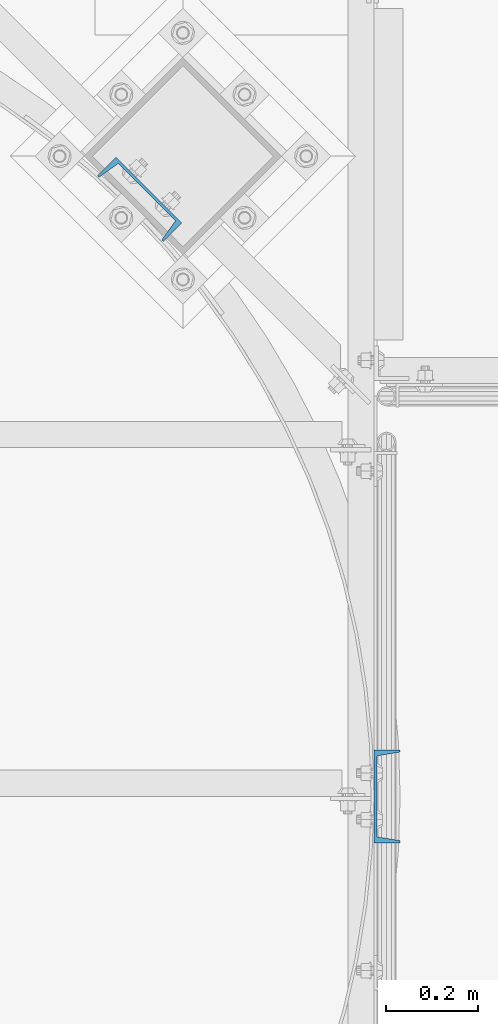
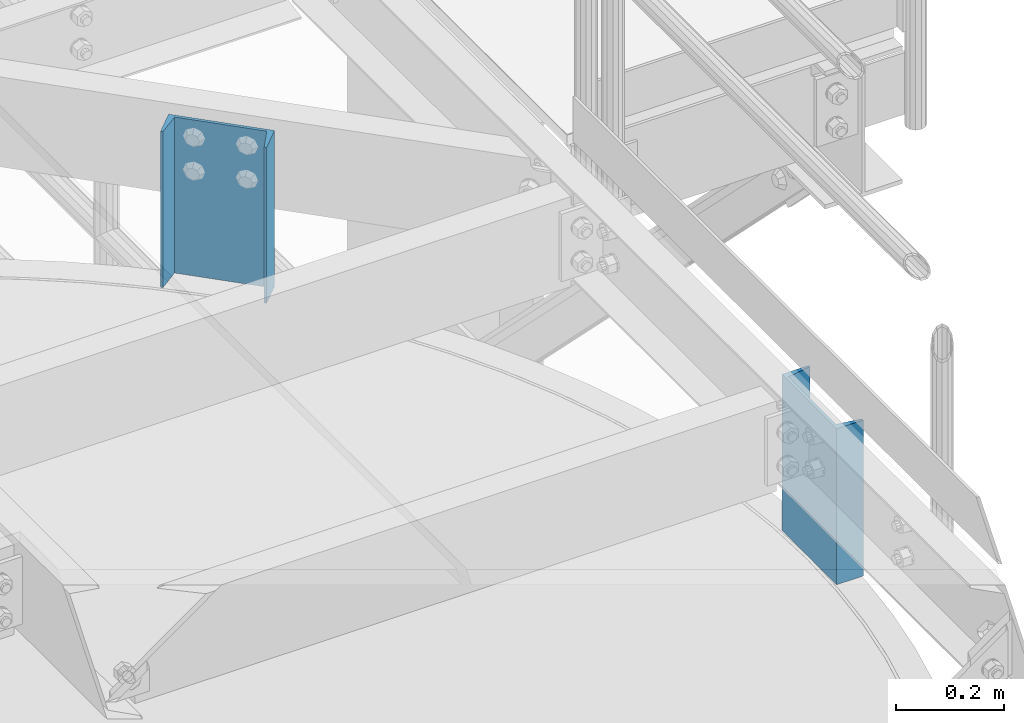
# One storey, part 807 of 1876: 2 columns, 2 elements without a shape of their own.
"""IFC2X3 building model written with IfcOpenShell, lengths in millimetres."""

from ifc_helpers import new_model, si_unit, frame, origin_with_axes, place, context, subcontext, project, spatial, faceted_brep, material, type_object, element, aggregate, save


model = new_model("IFC2X3")

# Units and contexts
model_context = context("Model", 3, precision=1e-05, world=origin_with_axes())
body_context = subcontext(model_context, "Body", "Model", "MODEL_VIEW")
ifc_project = project(units=[si_unit("LENGTHUNIT", "METRE", prefix="MILLI"), si_unit("AREAUNIT", "SQUARE_METRE"), si_unit("VOLUMEUNIT", "CUBIC_METRE"), si_unit("MASSUNIT", "GRAM", prefix="KILO"), si_unit("TIMEUNIT", "SECOND"), si_unit("PLANEANGLEUNIT", "RADIAN"), si_unit("SOLIDANGLEUNIT", "STERADIAN"), si_unit("THERMODYNAMICTEMPERATUREUNIT", "DEGREE_CELSIUS"), si_unit("LUMINOUSINTENSITYUNIT", "LUMEN")], contexts=[model_context])

# Site, building, storey
site_placement = place(None, origin_with_axes())
site = spatial("IfcSite", under=ifc_project, at=site_placement, CompositionType="ELEMENT")
building_placement = place(site_placement, origin_with_axes())
building = spatial("IfcBuilding", under=site, at=building_placement, Name="Undefined", CompositionType="ELEMENT")
storey_placement = place(building_placement, origin_with_axes())
storey = spatial("IfcBuildingStorey", under=building, at=storey_placement, Name="Undefined", CompositionType="ELEMENT", Elevation=0.0)

# Assembly, column
assembly_1_placement = place(storey_placement, origin_with_axes())
assembly_1 = element("IfcElementAssembly", 1, at=assembly_1_placement, inside=storey, Name="BEAM", AssemblyPlace="NOTDEFINED", PredefinedType="RIGID_FRAME")
ifc_material = material(Name="STEEL/A36")
column_type = type_object("IfcColumnType", Name="C8X11.5", PredefinedType="NOTDEFINED")
column_1_placement = place(assembly_1_placement, frame((7026.27547584742, -9537.66437988218, 7620.0), z_axis=(0.0, -1.0, 0.0), x_axis=(0.0, 0.0, 1.0)))
column_1 = element("IfcColumn", 2, at=column_1_placement, type_object=column_type, material=ifc_material, Name="BEAM", ObjectType="C8X11.5", context=body_context, shape_type="Brep", body=[
    faceted_brep([(0.0, 28.5749999999998, -101.6), (0.0, 28.5749999999998, 101.6), (352.425, 28.5749999999998, 101.6), (352.425, 28.5749999999998, -101.6), (0.0, -28.5749999999998, 101.6), (352.425, -28.5749999999998, 101.6), (0.0, -28.5749999999998, 96.8355950000005), (352.425, -28.5749999999998, 96.8355950000005), (0.0, 22.2250000000004, 88.3723150000005), (352.425, 22.2250000000004, 88.3723150000005), (0.0, 22.2250000000004, -88.3723150000005), (352.425, 22.2250000000004, -88.3723150000005), (0.0, -28.5749999999998, -96.8355950000005), (352.425, -28.5749999999998, -96.8355950000005), (0.0, -28.5749999999998, -101.6), (352.425, -28.5749999999998, -101.6)], [[[0, 1, 2, 3]], [[1, 4, 5, 2]], [[4, 6, 7, 5]], [[6, 8, 9, 7]], [[8, 10, 11, 9]], [[10, 12, 13, 11]], [[12, 14, 15, 13]], [[14, 0, 3, 15]], [[5, 7, 9, 11, 13, 15, 3, 2]], [[14, 12, 10, 8, 6, 4, 1, 0]]]),
])
aggregate(assembly_1, [column_1])

assembly_2_placement = place(storey_placement, origin_with_axes())
assembly_2 = element("IfcElementAssembly", 3, at=assembly_2_placement, inside=storey, Name="BEAM", AssemblyPlace="NOTDEFINED", PredefinedType="RIGID_FRAME")
column_2_placement = place(assembly_2_placement, frame((6485.96521257533, -8233.17237314777, 7620.0), z_axis=(-0.707106781186548, 0.707106781186547, 0.0), x_axis=(0.0, 0.0, 1.0)))
column_2 = element("IfcColumn", 4, at=column_2_placement, type_object=column_type, material=ifc_material, Name="BEAM", ObjectType="C8X11.5", context=body_context, shape_type="Brep", body=[
    faceted_brep([(0.0, 28.5749999999998, -101.6), (0.0, 28.5749999999998, 101.6), (352.425, 28.5749999999998, 101.6), (352.425, 28.5749999999998, -101.6), (0.0, -28.5749999999998, 101.6), (352.425, -28.5749999999998, 101.6), (0.0, -28.5749999999998, 96.8355950000005), (352.425, -28.5749999999998, 96.8355950000005), (0.0, 22.2250000000004, 88.3723150000005), (352.425, 22.2250000000004, 88.3723150000005), (0.0, 22.2250000000004, -88.3723150000005), (352.425, 22.2250000000004, -88.3723150000005), (0.0, -28.5749999999998, -96.8355950000005), (352.425, -28.5749999999998, -96.8355950000005), (0.0, -28.5749999999998, -101.6), (352.425, -28.5749999999998, -101.6)], [[[0, 1, 2, 3]], [[1, 4, 5, 2]], [[4, 6, 7, 5]], [[6, 8, 9, 7]], [[8, 10, 11, 9]], [[10, 12, 13, 11]], [[12, 14, 15, 13]], [[14, 0, 3, 15]], [[5, 7, 9, 11, 13, 15, 3, 2]], [[14, 12, 10, 8, 6, 4, 1, 0]]]),
])
aggregate(assembly_2, [column_2])

save(model, "model.ifc")
